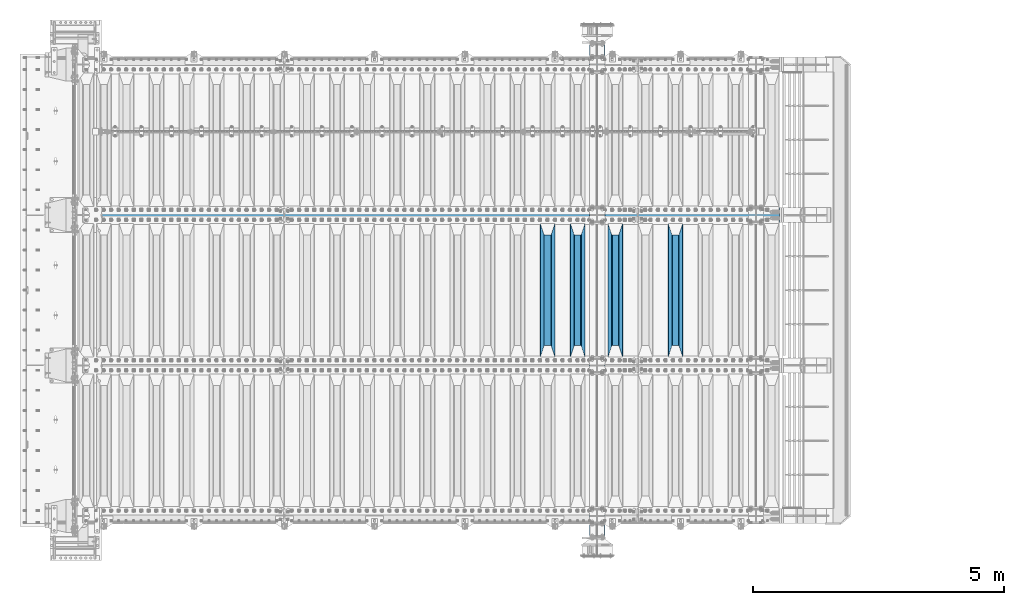
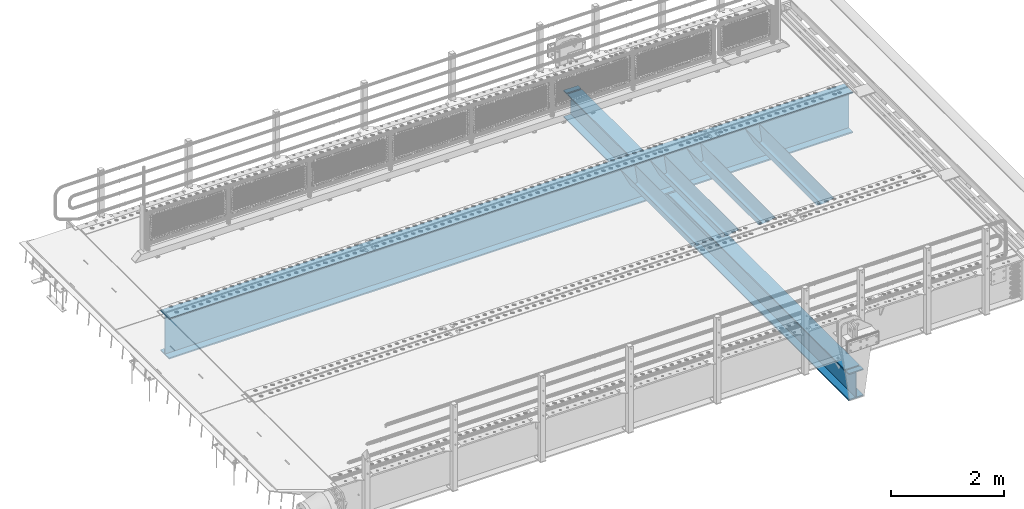
# One storey, part 106 of 219: 6 beams.
"""IFC2X3 building model written with IfcOpenShell, lengths in millimetres."""

from ifc_helpers import new_model, si_unit, frame, origin_with_axes, place, context, subcontext, project, spatial, faceted_brep, material, type_object, element, save


model = new_model("IFC2X3")

# Units and contexts
model_context = context("Model", 3, precision=1e-05, world=origin_with_axes())
body_context = subcontext(model_context, "Body", "Model", "MODEL_VIEW")
ifc_project = project(units=[si_unit("LENGTHUNIT", "METRE", prefix="MILLI"), si_unit("AREAUNIT", "SQUARE_METRE"), si_unit("VOLUMEUNIT", "CUBIC_METRE"), si_unit("MASSUNIT", "GRAM", prefix="KILO"), si_unit("TIMEUNIT", "SECOND"), si_unit("PLANEANGLEUNIT", "RADIAN"), si_unit("SOLIDANGLEUNIT", "STERADIAN"), si_unit("THERMODYNAMICTEMPERATUREUNIT", "DEGREE_CELSIUS"), si_unit("LUMINOUSINTENSITYUNIT", "LUMEN")], contexts=[model_context])

# Site, building, storey
site_placement = place(None, origin_with_axes())
site = spatial("IfcSite", under=ifc_project, at=site_placement, CompositionType="ELEMENT")
building_placement = place(site_placement, origin_with_axes())
building = spatial("IfcBuilding", under=site, at=building_placement, Name="Standard", CompositionType="ELEMENT")
storey_placement = place(building_placement, origin_with_axes())
storey = spatial("IfcBuildingStorey", under=building, at=storey_placement, Name="Undefined", CompositionType="ELEMENT", Elevation=0.0)

# Beams
ifc_material = material(Name="STEEL/S355N")
beam_type_1 = type_object("IfcBeamType", PredefinedType="NOTDEFINED")
beam_1_placement = place(storey_placement, frame((11950.0, 27175.0, -115.0), z_axis=(0.0, 0.0, 1.0), x_axis=(0.0, 1.0, 0.0)))
element("IfcBeam", 1, at=beam_1_placement, inside=storey, type_object=beam_type_1, material=ifc_material, context=body_context, shape_type="Brep", body=[
    faceted_brep([(0.0, 150.0, 115.0), (0.0, 143.690000000001, 115.0), (2650.00000000297, 143.690000000001, 115.0), (2650.00000000297, 150.0, 115.0), (2650.00000000297, 142.0595652184, 110.000000003094), (2650.00000000297, 148.3695652184, 110.000000003094), (2441.90079219209, -80.110360073113, -98.0992078077845), (2437.7588105432, -77.5672621345566, -102.241189456673), (2434.06523489747, -74.4080125315541, -105.934765102404), (2430.9108609509, -70.7102721255742, -109.089139048974), (2428.37322971128, -66.5649389910068, -111.626770288588), (2426.51472138055, -62.0739139532889, -113.485278619323), (2425.38102192092, -57.3475956567672, -114.618978078955), (2424.99999999988, -52.5021667386536, -115.0), (2424.99999999988, 52.5021667386536, -115.0), (2425.38102192092, 57.3475956567672, -114.618978078955), (2426.51472138055, 62.0739139532889, -113.485278619323), (2428.37322971128, 66.5649389910068, -111.626770288588), (2430.9108609509, 70.7102721255742, -109.089139048974), (2434.06523489747, 74.4080125315541, -105.934765102404), (2437.7588105432, 77.5672621345566, -102.241189456673), (2441.90079219209, 80.110360073113, -98.0992078077846), (2446.38936140512, 81.9747917625791, -93.6106385947584), (2448.2494850041, 76.2713538057269, -91.7505149957729), (2444.62967112263, 74.7677798626082, -95.3703288772456), (2441.28936334127, 72.7168944282894, -98.710636658607), (2438.31067330439, 70.1691124903828, -101.689326695487), (2435.76682334748, 67.1870637758839, -104.233176652398), (2433.72034654134, 63.8440531834913, -106.279653458539), (2432.22154950042, 60.2222587982342, -107.778450499454), (2431.30727574265, 56.4107117849107, -108.692724257221), (2430.99999999987, 52.5031078186894, -109.0), (2430.99999999987, -52.5031078186894, -109.0), (2431.30727574265, -56.4107117849107, -108.692724257221), (2432.22154950042, -60.2222587982342, -107.778450499454), (2433.72034654134, -63.8440531834913, -106.279653458539), (2435.76682334748, -67.1870637758839, -104.233176652398), (2438.31067330439, -70.1691124903828, -101.689326695487), (2441.28936334127, -72.7168944282894, -98.7106366586071), (2444.62967112263, -74.7677798626082, -95.3703288772457), (2448.2494850041, -76.2713538057269, -91.7505149957729), (2650.00000000297, -142.0595652184, 110.000000003094), (2650.00000000297, -148.3695652184, 110.000000003094), (2446.38936140512, -81.9747917625791, -93.6106385947584), (2650.00000000297, -143.690000000001, 115.0), (2650.00000000297, -150.0, 115.0), (0.0, -143.690000000001, 115.0), (0.0, -150.0, 115.0), (0.0, -148.369565218261, 110.000000002667), (203.610638597427, -81.9747917625791, -93.6106385947584), (208.09920781045, -80.110360073113, -98.0992078077845), (212.241189459342, -77.5672621345566, -102.241189456673), (215.93476510507, -74.4080125315541, -105.934765102404), (219.089139051641, -70.7102721255742, -109.089139048974), (221.626770291256, -66.5649389910068, -111.626770288588), (223.485278621989, -62.0739139532889, -113.485278619323), (224.618978081624, -57.3475956567672, -114.618978078955), (225.000000002663, -52.5021667386536, -115.0), (225.000000002663, 52.5021667386536, -115.0), (224.618978081624, 57.3475956567672, -114.618978078955), (223.485278621989, 62.0739139532889, -113.485278619323), (221.626770291256, 66.5649389910068, -111.626770288588), (219.089139051641, 70.7102721255742, -109.089139048974), (215.93476510507, 74.4080125315541, -105.934765102404), (212.241189459342, 77.5672621345566, -102.241189456673), (208.09920781045, 80.110360073113, -98.0992078077846), (203.610638597427, 81.9747917625791, -93.6106385947584), (0.0, 148.369565218261, 110.000000002667), (0.0, 142.059565218262, 110.000000002667), (201.750514998439, 76.2713538057269, -91.7505149957729), (205.370328879915, 74.7677798626082, -95.3703288772456), (208.710636661275, 72.7168944282894, -98.710636658607), (211.689326698157, 70.1691124903828, -101.689326695487), (214.233176655063, 67.1870637758839, -104.233176652398), (216.279653461206, 63.8440531834913, -106.279653458539), (217.778450502123, 60.2222587982342, -107.778450499454), (218.69272425989, 56.4107117849107, -108.692724257221), (219.00000000267, 52.5031078186894, -109.0), (219.00000000267, -52.5031078186894, -109.0), (218.69272425989, -56.4107117849107, -108.692724257221), (217.778450502123, -60.2222587982342, -107.778450499454), (216.279653461206, -63.8440531834913, -106.279653458539), (214.233176655063, -67.1870637758839, -104.233176652398), (211.689326698157, -70.1691124903828, -101.689326695487), (208.710636661275, -72.7168944282894, -98.7106366586071), (205.370328879915, -74.7677798626082, -95.3703288772457), (201.750514998439, -76.2713538057269, -91.7505149957729), (0.0, -142.059565218262, 110.000000002667)], [[[0, 1, 2, 3]], [[3, 2, 4, 5]], [[6, 7, 8, 9, 10, 11, 12, 13, 14, 15, 16, 17, 18, 19, 20, 21, 22, 5, 4, 23, 24, 25, 26, 27, 28, 29, 30, 31, 32, 33, 34, 35, 36, 37, 38, 39, 40, 41, 42, 43]], [[44, 45, 42, 41]], [[46, 47, 45, 44]], [[43, 42, 45, 47, 48, 49]], [[6, 43, 49, 50]], [[7, 6, 50, 51]], [[8, 7, 51, 52]], [[9, 8, 52, 53]], [[10, 9, 53, 54]], [[11, 10, 54, 55]], [[12, 11, 55, 56]], [[13, 12, 56, 57]], [[14, 13, 57, 58]], [[15, 14, 58, 59]], [[16, 15, 59, 60]], [[17, 16, 60, 61]], [[18, 17, 61, 62]], [[19, 18, 62, 63]], [[20, 19, 63, 64]], [[21, 20, 64, 65]], [[22, 21, 65, 66]], [[0, 3, 5, 22, 66, 67]], [[1, 0, 67, 68]], [[23, 4, 2, 1, 68, 69]], [[24, 23, 69, 70]], [[25, 24, 70, 71]], [[26, 25, 71, 72]], [[27, 26, 72, 73]], [[28, 27, 73, 74]], [[29, 28, 74, 75]], [[30, 29, 75, 76]], [[31, 30, 76, 77]], [[32, 31, 77, 78]], [[33, 32, 78, 79]], [[34, 33, 79, 80]], [[35, 34, 80, 81]], [[36, 35, 81, 82]], [[37, 36, 82, 83]], [[38, 37, 83, 84]], [[39, 38, 84, 85]], [[40, 39, 85, 86]], [[46, 44, 41, 40, 86, 87]], [[47, 46, 87, 48]], [[86, 85, 84, 83, 82, 81, 80, 79, 78, 77, 76, 75, 74, 73, 72, 71, 70, 69, 68, 67, 66, 65, 64, 63, 62, 61, 60, 59, 58, 57, 56, 55, 54, 53, 52, 51, 50, 49, 48, 87]]]),
])
beam_2_placement = place(storey_placement, frame((10750.0, 27175.0, -115.0), z_axis=(0.0, 0.0, 1.0), x_axis=(0.0, 1.0, 0.0)))
element("IfcBeam", 2, at=beam_2_placement, inside=storey, type_object=beam_type_1, material=ifc_material, context=body_context, shape_type="Brep", body=[
    faceted_brep([(0.0, 150.0, 115.0), (0.0, 143.690000000001, 115.0), (2650.00000000297, 143.690000000001, 115.0), (2650.00000000297, 150.0, 115.0), (2650.00000000297, 142.0595652184, 110.000000003094), (2650.00000000297, 148.3695652184, 110.000000003094), (2441.90079219209, -80.110360073113, -98.0992078077845), (2437.7588105432, -77.5672621345566, -102.241189456673), (2434.06523489747, -74.4080125315541, -105.934765102404), (2430.9108609509, -70.7102721255742, -109.089139048974), (2428.37322971128, -66.5649389910068, -111.626770288588), (2426.51472138055, -62.0739139532889, -113.485278619323), (2425.38102192092, -57.3475956567672, -114.618978078955), (2424.99999999988, -52.5021667386536, -115.0), (2424.99999999988, 52.5021667386536, -115.0), (2425.38102192092, 57.3475956567672, -114.618978078955), (2426.51472138055, 62.0739139532889, -113.485278619323), (2428.37322971128, 66.5649389910068, -111.626770288588), (2430.9108609509, 70.7102721255742, -109.089139048974), (2434.06523489747, 74.4080125315541, -105.934765102404), (2437.7588105432, 77.5672621345566, -102.241189456673), (2441.90079219209, 80.110360073113, -98.0992078077846), (2446.38936140512, 81.9747917625791, -93.6106385947584), (2448.2494850041, 76.2713538057269, -91.7505149957729), (2444.62967112263, 74.7677798626082, -95.3703288772456), (2441.28936334127, 72.7168944282894, -98.710636658607), (2438.31067330439, 70.1691124903828, -101.689326695487), (2435.76682334748, 67.1870637758839, -104.233176652398), (2433.72034654134, 63.8440531834913, -106.279653458539), (2432.22154950042, 60.2222587982342, -107.778450499454), (2431.30727574265, 56.4107117849107, -108.692724257221), (2430.99999999987, 52.5031078186894, -109.0), (2430.99999999987, -52.5031078186894, -109.0), (2431.30727574265, -56.4107117849107, -108.692724257221), (2432.22154950042, -60.2222587982342, -107.778450499454), (2433.72034654134, -63.8440531834913, -106.279653458539), (2435.76682334748, -67.1870637758839, -104.233176652398), (2438.31067330439, -70.1691124903828, -101.689326695487), (2441.28936334127, -72.7168944282894, -98.7106366586071), (2444.62967112263, -74.7677798626082, -95.3703288772457), (2448.2494850041, -76.2713538057269, -91.7505149957729), (2650.00000000297, -142.0595652184, 110.000000003094), (2650.00000000297, -148.3695652184, 110.000000003094), (2446.38936140512, -81.9747917625791, -93.6106385947584), (2650.00000000297, -143.690000000001, 115.0), (2650.00000000297, -150.0, 115.0), (0.0, -143.690000000001, 115.0), (0.0, -150.0, 115.0), (0.0, -148.369565218261, 110.000000002667), (203.610638597427, -81.9747917625791, -93.6106385947584), (208.09920781045, -80.110360073113, -98.0992078077845), (212.241189459342, -77.5672621345566, -102.241189456673), (215.93476510507, -74.4080125315541, -105.934765102404), (219.089139051641, -70.7102721255742, -109.089139048974), (221.626770291256, -66.5649389910068, -111.626770288588), (223.485278621989, -62.0739139532889, -113.485278619323), (224.618978081624, -57.3475956567672, -114.618978078955), (225.000000002663, -52.5021667386536, -115.0), (225.000000002663, 52.5021667386536, -115.0), (224.618978081624, 57.3475956567672, -114.618978078955), (223.485278621989, 62.0739139532889, -113.485278619323), (221.626770291256, 66.5649389910068, -111.626770288588), (219.089139051641, 70.7102721255742, -109.089139048974), (215.93476510507, 74.4080125315541, -105.934765102404), (212.241189459342, 77.5672621345566, -102.241189456673), (208.09920781045, 80.110360073113, -98.0992078077846), (203.610638597427, 81.9747917625791, -93.6106385947584), (0.0, 148.369565218261, 110.000000002667), (0.0, 142.059565218262, 110.000000002667), (201.750514998439, 76.2713538057269, -91.7505149957729), (205.370328879915, 74.7677798626082, -95.3703288772456), (208.710636661275, 72.7168944282894, -98.710636658607), (211.689326698157, 70.1691124903828, -101.689326695487), (214.233176655063, 67.1870637758839, -104.233176652398), (216.279653461206, 63.8440531834913, -106.279653458539), (217.778450502123, 60.2222587982342, -107.778450499454), (218.69272425989, 56.4107117849107, -108.692724257221), (219.00000000267, 52.5031078186894, -109.0), (219.00000000267, -52.5031078186894, -109.0), (218.69272425989, -56.4107117849107, -108.692724257221), (217.778450502123, -60.2222587982342, -107.778450499454), (216.279653461206, -63.8440531834913, -106.279653458539), (214.233176655063, -67.1870637758839, -104.233176652398), (211.689326698157, -70.1691124903828, -101.689326695487), (208.710636661275, -72.7168944282894, -98.7106366586071), (205.370328879915, -74.7677798626082, -95.3703288772457), (201.750514998439, -76.2713538057269, -91.7505149957729), (0.0, -142.059565218262, 110.000000002667)], [[[0, 1, 2, 3]], [[3, 2, 4, 5]], [[6, 7, 8, 9, 10, 11, 12, 13, 14, 15, 16, 17, 18, 19, 20, 21, 22, 5, 4, 23, 24, 25, 26, 27, 28, 29, 30, 31, 32, 33, 34, 35, 36, 37, 38, 39, 40, 41, 42, 43]], [[44, 45, 42, 41]], [[46, 47, 45, 44]], [[43, 42, 45, 47, 48, 49]], [[6, 43, 49, 50]], [[7, 6, 50, 51]], [[8, 7, 51, 52]], [[9, 8, 52, 53]], [[10, 9, 53, 54]], [[11, 10, 54, 55]], [[12, 11, 55, 56]], [[13, 12, 56, 57]], [[14, 13, 57, 58]], [[15, 14, 58, 59]], [[16, 15, 59, 60]], [[17, 16, 60, 61]], [[18, 17, 61, 62]], [[19, 18, 62, 63]], [[20, 19, 63, 64]], [[21, 20, 64, 65]], [[22, 21, 65, 66]], [[0, 3, 5, 22, 66, 67]], [[1, 0, 67, 68]], [[23, 4, 2, 1, 68, 69]], [[24, 23, 69, 70]], [[25, 24, 70, 71]], [[26, 25, 71, 72]], [[27, 26, 72, 73]], [[28, 27, 73, 74]], [[29, 28, 74, 75]], [[30, 29, 75, 76]], [[31, 30, 76, 77]], [[32, 31, 77, 78]], [[33, 32, 78, 79]], [[34, 33, 79, 80]], [[35, 34, 80, 81]], [[36, 35, 81, 82]], [[37, 36, 82, 83]], [[38, 37, 83, 84]], [[39, 38, 84, 85]], [[40, 39, 85, 86]], [[46, 44, 41, 40, 86, 87]], [[47, 46, 87, 48]], [[86, 85, 84, 83, 82, 81, 80, 79, 78, 77, 76, 75, 74, 73, 72, 71, 70, 69, 68, 67, 66, 65, 64, 63, 62, 61, 60, 59, 58, 57, 56, 55, 54, 53, 52, 51, 50, 49, 48, 87]]]),
])
beam_3_placement = place(storey_placement, frame((10000.0, 27175.0, -115.0), z_axis=(0.0, 0.0, 1.0), x_axis=(0.0, 1.0, 0.0)))
element("IfcBeam", 3, at=beam_3_placement, inside=storey, type_object=beam_type_1, material=ifc_material, context=body_context, shape_type="Brep", body=[
    faceted_brep([(0.0, 150.0, 115.0), (0.0, 143.690000000001, 115.0), (2650.00000000297, 143.690000000001, 115.0), (2650.00000000297, 150.0, 115.0), (2650.00000000297, 142.0595652184, 110.000000003094), (2650.00000000297, 148.3695652184, 110.000000003094), (2441.90079219209, -80.110360073113, -98.0992078077845), (2437.7588105432, -77.5672621345566, -102.241189456673), (2434.06523489747, -74.4080125315541, -105.934765102404), (2430.9108609509, -70.7102721255742, -109.089139048974), (2428.37322971128, -66.5649389910068, -111.626770288588), (2426.51472138055, -62.0739139532889, -113.485278619323), (2425.38102192092, -57.3475956567672, -114.618978078955), (2424.99999999988, -52.5021667386536, -115.0), (2424.99999999988, 52.5021667386536, -115.0), (2425.38102192092, 57.3475956567672, -114.618978078955), (2426.51472138055, 62.0739139532889, -113.485278619323), (2428.37322971128, 66.5649389910068, -111.626770288588), (2430.9108609509, 70.7102721255742, -109.089139048974), (2434.06523489747, 74.4080125315541, -105.934765102404), (2437.7588105432, 77.5672621345566, -102.241189456673), (2441.90079219209, 80.110360073113, -98.0992078077846), (2446.38936140512, 81.9747917625791, -93.6106385947584), (2448.2494850041, 76.2713538057269, -91.7505149957729), (2444.62967112263, 74.7677798626082, -95.3703288772456), (2441.28936334127, 72.7168944282894, -98.710636658607), (2438.31067330439, 70.1691124903828, -101.689326695487), (2435.76682334748, 67.1870637758839, -104.233176652398), (2433.72034654134, 63.8440531834913, -106.279653458539), (2432.22154950042, 60.2222587982342, -107.778450499454), (2431.30727574265, 56.4107117849107, -108.692724257221), (2430.99999999987, 52.5031078186894, -109.0), (2430.99999999987, -52.5031078186894, -109.0), (2431.30727574265, -56.4107117849107, -108.692724257221), (2432.22154950042, -60.2222587982342, -107.778450499454), (2433.72034654134, -63.8440531834913, -106.279653458539), (2435.76682334748, -67.1870637758839, -104.233176652398), (2438.31067330439, -70.1691124903828, -101.689326695487), (2441.28936334127, -72.7168944282894, -98.7106366586071), (2444.62967112263, -74.7677798626082, -95.3703288772457), (2448.2494850041, -76.2713538057269, -91.7505149957729), (2650.00000000297, -142.0595652184, 110.000000003094), (2650.00000000297, -148.3695652184, 110.000000003094), (2446.38936140512, -81.9747917625791, -93.6106385947584), (2650.00000000297, -143.690000000001, 115.0), (2650.00000000297, -150.0, 115.0), (0.0, -143.690000000001, 115.0), (0.0, -150.0, 115.0), (0.0, -148.369565218261, 110.000000002667), (203.610638597427, -81.9747917625791, -93.6106385947584), (208.09920781045, -80.110360073113, -98.0992078077845), (212.241189459342, -77.5672621345566, -102.241189456673), (215.93476510507, -74.4080125315541, -105.934765102404), (219.089139051641, -70.7102721255742, -109.089139048974), (221.626770291256, -66.5649389910068, -111.626770288588), (223.485278621989, -62.0739139532889, -113.485278619323), (224.618978081624, -57.3475956567672, -114.618978078955), (225.000000002663, -52.5021667386536, -115.0), (225.000000002663, 52.5021667386536, -115.0), (224.618978081624, 57.3475956567672, -114.618978078955), (223.485278621989, 62.0739139532889, -113.485278619323), (221.626770291256, 66.5649389910068, -111.626770288588), (219.089139051641, 70.7102721255742, -109.089139048974), (215.93476510507, 74.4080125315541, -105.934765102404), (212.241189459342, 77.5672621345566, -102.241189456673), (208.09920781045, 80.110360073113, -98.0992078077846), (203.610638597427, 81.9747917625791, -93.6106385947584), (0.0, 148.369565218261, 110.000000002667), (0.0, 142.059565218262, 110.000000002667), (201.750514998439, 76.2713538057269, -91.7505149957729), (205.370328879915, 74.7677798626082, -95.3703288772456), (208.710636661275, 72.7168944282894, -98.710636658607), (211.689326698157, 70.1691124903828, -101.689326695487), (214.233176655063, 67.1870637758839, -104.233176652398), (216.279653461206, 63.8440531834913, -106.279653458539), (217.778450502123, 60.2222587982342, -107.778450499454), (218.69272425989, 56.4107117849107, -108.692724257221), (219.00000000267, 52.5031078186894, -109.0), (219.00000000267, -52.5031078186894, -109.0), (218.69272425989, -56.4107117849107, -108.692724257221), (217.778450502123, -60.2222587982342, -107.778450499454), (216.279653461206, -63.8440531834913, -106.279653458539), (214.233176655063, -67.1870637758839, -104.233176652398), (211.689326698157, -70.1691124903828, -101.689326695487), (208.710636661275, -72.7168944282894, -98.7106366586071), (205.370328879915, -74.7677798626082, -95.3703288772457), (201.750514998439, -76.2713538057269, -91.7505149957729), (0.0, -142.059565218262, 110.000000002667)], [[[0, 1, 2, 3]], [[3, 2, 4, 5]], [[6, 7, 8, 9, 10, 11, 12, 13, 14, 15, 16, 17, 18, 19, 20, 21, 22, 5, 4, 23, 24, 25, 26, 27, 28, 29, 30, 31, 32, 33, 34, 35, 36, 37, 38, 39, 40, 41, 42, 43]], [[44, 45, 42, 41]], [[46, 47, 45, 44]], [[43, 42, 45, 47, 48, 49]], [[6, 43, 49, 50]], [[7, 6, 50, 51]], [[8, 7, 51, 52]], [[9, 8, 52, 53]], [[10, 9, 53, 54]], [[11, 10, 54, 55]], [[12, 11, 55, 56]], [[13, 12, 56, 57]], [[14, 13, 57, 58]], [[15, 14, 58, 59]], [[16, 15, 59, 60]], [[17, 16, 60, 61]], [[18, 17, 61, 62]], [[19, 18, 62, 63]], [[20, 19, 63, 64]], [[21, 20, 64, 65]], [[22, 21, 65, 66]], [[0, 3, 5, 22, 66, 67]], [[1, 0, 67, 68]], [[23, 4, 2, 1, 68, 69]], [[24, 23, 69, 70]], [[25, 24, 70, 71]], [[26, 25, 71, 72]], [[27, 26, 72, 73]], [[28, 27, 73, 74]], [[29, 28, 74, 75]], [[30, 29, 75, 76]], [[31, 30, 76, 77]], [[32, 31, 77, 78]], [[33, 32, 78, 79]], [[34, 33, 79, 80]], [[35, 34, 80, 81]], [[36, 35, 81, 82]], [[37, 36, 82, 83]], [[38, 37, 83, 84]], [[39, 38, 84, 85]], [[40, 39, 85, 86]], [[46, 44, 41, 40, 86, 87]], [[47, 46, 87, 48]], [[86, 85, 84, 83, 82, 81, 80, 79, 78, 77, 76, 75, 74, 73, 72, 71, 70, 69, 68, 67, 66, 65, 64, 63, 62, 61, 60, 59, 58, 57, 56, 55, 54, 53, 52, 51, 50, 49, 48, 87]]]),
])
beam_4_placement = place(storey_placement, frame((9400.0, 27175.0, -115.0), z_axis=(0.0, 0.0, 1.0), x_axis=(0.0, 1.0, 0.0)))
element("IfcBeam", 4, at=beam_4_placement, inside=storey, type_object=beam_type_1, material=ifc_material, context=body_context, shape_type="Brep", body=[
    faceted_brep([(0.0, 150.0, 115.0), (0.0, 143.690000000001, 115.0), (2650.00000000297, 143.690000000001, 115.0), (2650.00000000297, 150.0, 115.0), (2650.00000000297, 142.0595652184, 110.000000003094), (2650.00000000297, 148.3695652184, 110.000000003094), (2441.90079219209, -80.110360073113, -98.0992078077845), (2437.7588105432, -77.5672621345566, -102.241189456673), (2434.06523489747, -74.4080125315541, -105.934765102404), (2430.9108609509, -70.7102721255742, -109.089139048974), (2428.37322971128, -66.5649389910068, -111.626770288588), (2426.51472138055, -62.0739139532889, -113.485278619323), (2425.38102192092, -57.3475956567672, -114.618978078955), (2424.99999999988, -52.5021667386536, -115.0), (2424.99999999988, 52.5021667386536, -115.0), (2425.38102192092, 57.3475956567672, -114.618978078955), (2426.51472138055, 62.0739139532889, -113.485278619323), (2428.37322971128, 66.5649389910068, -111.626770288588), (2430.9108609509, 70.7102721255742, -109.089139048974), (2434.06523489747, 74.4080125315541, -105.934765102404), (2437.7588105432, 77.5672621345566, -102.241189456673), (2441.90079219209, 80.110360073113, -98.0992078077846), (2446.38936140512, 81.9747917625791, -93.6106385947584), (2448.2494850041, 76.2713538057269, -91.7505149957729), (2444.62967112263, 74.7677798626082, -95.3703288772456), (2441.28936334127, 72.7168944282894, -98.710636658607), (2438.31067330439, 70.1691124903828, -101.689326695487), (2435.76682334748, 67.1870637758839, -104.233176652398), (2433.72034654134, 63.8440531834913, -106.279653458539), (2432.22154950042, 60.2222587982342, -107.778450499454), (2431.30727574265, 56.4107117849107, -108.692724257221), (2430.99999999987, 52.5031078186894, -109.0), (2430.99999999987, -52.5031078186894, -109.0), (2431.30727574265, -56.4107117849107, -108.692724257221), (2432.22154950042, -60.2222587982342, -107.778450499454), (2433.72034654134, -63.8440531834913, -106.279653458539), (2435.76682334748, -67.1870637758839, -104.233176652398), (2438.31067330439, -70.1691124903828, -101.689326695487), (2441.28936334127, -72.7168944282894, -98.7106366586071), (2444.62967112263, -74.7677798626082, -95.3703288772457), (2448.2494850041, -76.2713538057269, -91.7505149957729), (2650.00000000297, -142.0595652184, 110.000000003094), (2650.00000000297, -148.3695652184, 110.000000003094), (2446.38936140512, -81.9747917625791, -93.6106385947584), (2650.00000000297, -143.690000000001, 115.0), (2650.00000000297, -150.0, 115.0), (0.0, -143.690000000001, 115.0), (0.0, -150.0, 115.0), (0.0, -148.369565218261, 110.000000002667), (203.610638597427, -81.9747917625791, -93.6106385947584), (208.09920781045, -80.110360073113, -98.0992078077845), (212.241189459342, -77.5672621345566, -102.241189456673), (215.93476510507, -74.4080125315541, -105.934765102404), (219.089139051641, -70.7102721255742, -109.089139048974), (221.626770291256, -66.5649389910068, -111.626770288588), (223.485278621989, -62.0739139532889, -113.485278619323), (224.618978081624, -57.3475956567672, -114.618978078955), (225.000000002663, -52.5021667386536, -115.0), (225.000000002663, 52.5021667386536, -115.0), (224.618978081624, 57.3475956567672, -114.618978078955), (223.485278621989, 62.0739139532889, -113.485278619323), (221.626770291256, 66.5649389910068, -111.626770288588), (219.089139051641, 70.7102721255742, -109.089139048974), (215.93476510507, 74.4080125315541, -105.934765102404), (212.241189459342, 77.5672621345566, -102.241189456673), (208.09920781045, 80.110360073113, -98.0992078077846), (203.610638597427, 81.9747917625791, -93.6106385947584), (0.0, 148.369565218261, 110.000000002667), (0.0, 142.059565218262, 110.000000002667), (201.750514998439, 76.2713538057269, -91.7505149957729), (205.370328879915, 74.7677798626082, -95.3703288772456), (208.710636661275, 72.7168944282894, -98.710636658607), (211.689326698157, 70.1691124903828, -101.689326695487), (214.233176655063, 67.1870637758839, -104.233176652398), (216.279653461206, 63.8440531834913, -106.279653458539), (217.778450502123, 60.2222587982342, -107.778450499454), (218.69272425989, 56.4107117849107, -108.692724257221), (219.00000000267, 52.5031078186894, -109.0), (219.00000000267, -52.5031078186894, -109.0), (218.69272425989, -56.4107117849107, -108.692724257221), (217.778450502123, -60.2222587982342, -107.778450499454), (216.279653461206, -63.8440531834913, -106.279653458539), (214.233176655063, -67.1870637758839, -104.233176652398), (211.689326698157, -70.1691124903828, -101.689326695487), (208.710636661275, -72.7168944282894, -98.7106366586071), (205.370328879915, -74.7677798626082, -95.3703288772457), (201.750514998439, -76.2713538057269, -91.7505149957729), (0.0, -142.059565218262, 110.000000002667)], [[[0, 1, 2, 3]], [[3, 2, 4, 5]], [[6, 7, 8, 9, 10, 11, 12, 13, 14, 15, 16, 17, 18, 19, 20, 21, 22, 5, 4, 23, 24, 25, 26, 27, 28, 29, 30, 31, 32, 33, 34, 35, 36, 37, 38, 39, 40, 41, 42, 43]], [[44, 45, 42, 41]], [[46, 47, 45, 44]], [[43, 42, 45, 47, 48, 49]], [[6, 43, 49, 50]], [[7, 6, 50, 51]], [[8, 7, 51, 52]], [[9, 8, 52, 53]], [[10, 9, 53, 54]], [[11, 10, 54, 55]], [[12, 11, 55, 56]], [[13, 12, 56, 57]], [[14, 13, 57, 58]], [[15, 14, 58, 59]], [[16, 15, 59, 60]], [[17, 16, 60, 61]], [[18, 17, 61, 62]], [[19, 18, 62, 63]], [[20, 19, 63, 64]], [[21, 20, 64, 65]], [[22, 21, 65, 66]], [[0, 3, 5, 22, 66, 67]], [[1, 0, 67, 68]], [[23, 4, 2, 1, 68, 69]], [[24, 23, 69, 70]], [[25, 24, 70, 71]], [[26, 25, 71, 72]], [[27, 26, 72, 73]], [[28, 27, 73, 74]], [[29, 28, 74, 75]], [[30, 29, 75, 76]], [[31, 30, 76, 77]], [[32, 31, 77, 78]], [[33, 32, 78, 79]], [[34, 33, 79, 80]], [[35, 34, 80, 81]], [[36, 35, 81, 82]], [[37, 36, 82, 83]], [[38, 37, 83, 84]], [[39, 38, 84, 85]], [[40, 39, 85, 86]], [[46, 44, 41, 40, 86, 87]], [[47, 46, 87, 48]], [[86, 85, 84, 83, 82, 81, 80, 79, 78, 77, 76, 75, 74, 73, 72, 71, 70, 69, 68, 67, 66, 65, 64, 63, 62, 61, 60, 59, 58, 57, 56, 55, 54, 53, 52, 51, 50, 49, 48, 87]]]),
])
beam_type_2 = type_object("IfcBeamType", Name="HEA900", PredefinedType="NOTDEFINED")
beam_5_placement = place(storey_placement, frame((10.0, 30000.0, -445.0), z_axis=(0.0, 0.0, 1.0), x_axis=(1.0, 0.0, 0.0)))
element("IfcBeam", 5, at=beam_5_placement, inside=storey, type_object=beam_type_2, material=ifc_material, ObjectType="HEA900", context=body_context, shape_type="Brep", body=[
    faceted_brep([(0.0, 150.0, -445.0), (0.0, 150.0, -415.0), (14017.0, 150.0, -415.0), (14017.0, 150.0, -445.0), (0.0, 8.0, -415.0), (14017.0, 8.0, -415.0), (0.0, 8.0, 415.0), (14017.0, 8.0, 415.0), (0.0, 150.0, 415.0), (14017.0, 150.0, 415.0), (0.0, 150.0, 445.0), (14017.0, 150.0, 445.0), (0.0, -150.0, 445.0), (14017.0, -150.0, 445.0), (0.0, -150.0, 415.0), (14017.0, -150.0, 415.0), (0.0, -8.0, 415.0), (14017.0, -8.0, 415.0), (0.0, -8.0, -415.0), (14017.0, -8.0, -415.0), (0.0, -150.0, -415.0), (14017.0, -150.0, -415.0), (0.0, -150.0, -445.0), (14017.0, -150.0, -445.0)], [[[0, 1, 2, 3]], [[1, 4, 5, 2]], [[4, 6, 7, 5]], [[6, 8, 9, 7]], [[8, 10, 11, 9]], [[10, 12, 13, 11]], [[12, 14, 15, 13]], [[14, 16, 17, 15]], [[16, 18, 19, 17]], [[18, 20, 21, 19]], [[20, 22, 23, 21]], [[22, 0, 3, 23]], [[5, 7, 9, 11, 13, 15, 17, 19, 21, 23, 3, 2]], [[22, 20, 18, 16, 14, 12, 10, 8, 6, 4, 1, 0]]]),
])
beam_type_3 = type_object("IfcBeamType", Name="HEA600", PredefinedType="NOTDEFINED")
beam_6_placement = place(storey_placement, frame((10389.9999999349, 23434.9999999853, -1185.00001823837), z_axis=(0.0, 0.0, 1.0), x_axis=(0.0, 1.0, 0.0)))
element("IfcBeam", 6, at=beam_6_placement, inside=storey, type_object=beam_type_3, material=ifc_material, ObjectType="HEA600", context=body_context, shape_type="Brep", body=[
    faceted_brep([(9989.99999999953, -150.000000001211, 295.0), (9989.99999999953, -150.0, 270.0), (9989.99999999953, -6.5, 270.0), (9989.99999999953, -6.5, 295.0), (10019.9999999995, -6.5, 270.0), (10019.9999999995, -6.5, 295.0), (10019.9999999995, -150.0, 295.0), (10019.9999999995, -150.0, 270.0), (10129.9999999995, -150.0, 270.0), (10129.9999999995, -150.0, 295.0), (10129.9999999995, -6.5, 270.0), (10129.9999999995, 150.0, 295.0), (10129.9999999995, 150.0, 270.0), (10019.9999999995, 150.0, 270.0), (10019.9999999995, 150.0, 295.0), (140.000000143944, 6.5, 270.0), (140.000000424465, 150.0, 270.0), (9989.99999999953, 150.0, 270.0), (9989.99999999953, 6.5, 270.0), (0.0, -150.0, -295.0), (0.0, 150.0, -295.0), (10129.9999999995, 150.0, -295.0), (10129.9999999995, -150.0, -295.0), (10019.9999999995, -150.0, -270.0), (9989.99999999953, -150.0, -270.0), (139.999999837913, -150.0, -270.0), (109.999999837913, -150.0, -270.0), (0.0, -150.0, -270.0), (10129.9999999995, -150.0, -270.0), (10019.9999999995, -6.5, -270.0), (9989.99999999953, -6.5, -270.0), (140.00000012475, -6.5, -270.0), (110.000000124914, -6.5, -270.0), (0.0, -6.5, -270.0), (10129.9999999995, -6.5, -270.0), (0.0, -150.0, 270.0), (0.0, -6.5, 270.0), (110.000000124914, -6.5, 270.0), (109.999999837913, -150.0, 270.0), (139.999999837913, -150.00000008646, 295.0), (140.00000012475, -6.5000000864602, 295.0), (140.00000012475, -6.5, 270.0), (139.999999837913, -150.0, 270.0), (110.000000124914, -6.50000002646084, 295.0), (109.999999837913, -150.0, 295.0), (0.0, -150.0, 295.0), (0.0, 6.5, 270.0), (0.0, 150.0, 270.0), (110.000000424465, 150.0, 270.0), (110.000000424465, 6.5, 270.0), (0.0, 150.0, 295.0), (0.0, 6.5, -270.0), (0.0, 150.0, -270.0), (110.000000424465, 150.0, 295.0), (110.000000424465, 6.49999991434379, 295.0), (140.000000143944, 6.49999991434379, 295.0), (140.000000424465, 150.0, 295.0), (9989.99999999953, 150.0, 295.0), (9989.99999999953, 6.5, 295.0), (10019.9999999995, 6.5, 295.0), (10019.9999999995, 6.5, 270.0), (10129.9999999995, 6.5, 270.0), (10019.9999999995, 6.5, -270.0), (9989.99999999953, 6.5, -270.0), (140.000000143944, 6.5, -270.0), (110.000000424465, 6.5, -270.0), (10129.9999999995, 6.5, -270.0), (10019.9999999995, 150.0, -270.0), (9989.99999999953, 150.0, -270.0), (140.000000424465, 150.0, -270.0), (110.000000424465, 150.0, -270.0), (10129.9999999995, 150.0, -270.0)], [[[0, 1, 2, 3]], [[3, 2, 4, 5]], [[6, 5, 4, 7]], [[8, 9, 6, 7]], [[10, 8, 7, 4]], [[11, 12, 13, 14]], [[15, 16, 17, 18]], [[19, 20, 21, 22]], [[23, 24, 25, 26, 27, 19, 22, 28]], [[29, 30, 31, 32, 33, 27, 26, 25, 24, 23, 28, 34]], [[35, 36, 37, 38]], [[39, 40, 41, 42]], [[43, 37, 41, 40]], [[44, 38, 37, 43]], [[45, 35, 38, 44]], [[46, 47, 48, 49]], [[19, 27, 33, 36, 35, 45, 50, 47, 46, 51, 52, 20]], [[47, 50, 53, 48]], [[54, 49, 48, 53]], [[55, 15, 49, 54]], [[56, 16, 15, 55]], [[16, 56, 57, 17]], [[58, 18, 17, 57]], [[59, 60, 18, 58]], [[14, 13, 60, 59]], [[12, 61, 60, 13]], [[62, 63, 64, 65, 51, 46, 49, 15, 18, 60, 61, 66]], [[67, 68, 69, 70, 52, 51, 65, 64, 63, 62, 66, 71]], [[20, 52, 70, 69, 68, 67, 71, 21]], [[66, 61, 12, 11, 9, 8, 10, 34, 28, 22, 21, 71]], [[4, 2, 41, 37, 36, 33, 32, 31, 30, 29, 34, 10]], [[42, 41, 2, 1]], [[39, 42, 1, 0]], [[9, 11, 14, 59, 58, 57, 56, 55, 54, 53, 50, 45, 44, 43, 40, 39, 0, 3, 5, 6]]]),
])

save(model, "model.ifc")
